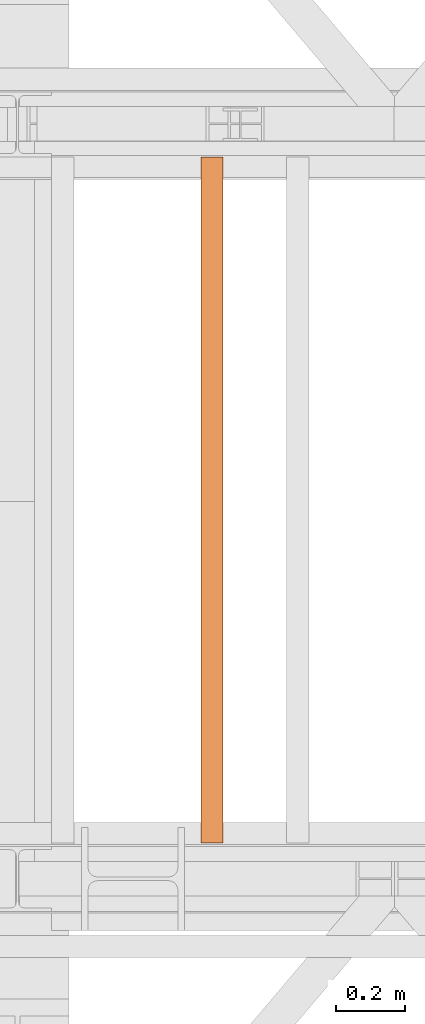
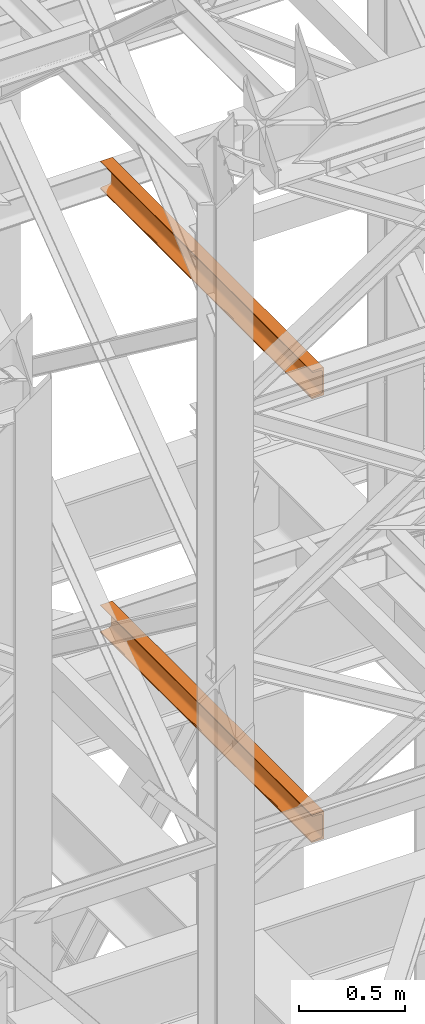
# One storey, part 156 of 208: 2 proxies.
"""IFC2X3 building model written with IfcOpenShell, lengths in millimetres."""

from ifc_helpers import new_model, entity, si_unit, converted_unit, frame, origin, origin_with_axes, place, context, subcontext, project, spatial, faceted_brep, element, save


model = new_model("IFC2X3")

# Units and contexts
model_context = context("Model", 3, precision=1e-05, world=origin())
plan_context = context("Plan", 3, precision=1e-05, world=origin())
body_context = subcontext(model_context, "Body", "Model", "MODEL_VIEW")
ifc_project = project(units=[si_unit("LENGTHUNIT", "METRE", prefix="MILLI"), converted_unit("PLANEANGLEUNIT", "DEGREE", entity("IfcPlaneAngleMeasure", 0.0174532925199433), si_unit("PLANEANGLEUNIT", "RADIAN"), dimensions=[0, 0, 0, 0, 0, 0, 0]), si_unit("AREAUNIT", "SQUARE_METRE"), si_unit("VOLUMEUNIT", "CUBIC_METRE")], contexts=[model_context, plan_context])

# Building, storey
building_placement = place(None, origin())
building = spatial("IfcBuilding", under=ifc_project, at=building_placement, CompositionType="COMPLEX")
storey_placement = place(building_placement, origin_with_axes())
storey = spatial("IfcBuildingStorey", under=building, at=storey_placement, Name="Geschoss", CompositionType="ELEMENT")

# Proxies
proxy_1_placement = place(storey_placement, frame((3828.254968528666, -15857.57439274273, 5524.960005364417), z_axis=(0.0, 0.0, 1.0), x_axis=(1.0, 0.0, 0.0)))
element("IfcBuildingElementProxy", 1, at=proxy_1_placement, inside=storey, context=body_context, shape_type="Brep", body=[
    faceted_brep([(65.01000000000022, 2000.009997019768, 160.0100000000002), (65.01000000000158, 0.01000000000021828, 160.0100000000002), (0.01000000000158252, 0.01000000000021828, 160.0100000000002), (0.01000000000021828, 2000.009997019768, 160.0100000000002), (0.01000000000021828, 2000.009997019768, 160.0100000000002), (0.01000000000158252, 0.01000000000021828, 160.0100000000002), (0.01000000000158252, 0.01000000000021828, 156.8875719297539), (0.01000000000021828, 2000.009997019768, 156.8875719297539), (0.01000000000021828, 2000.009997019768, 156.8875719297539), (0.01000000000158252, 0.01000000000021828, 156.8875719297539), (0.2527365771743462, 0.01000000000021828, 155.2717110918293), (0.2527365771729819, 2000.009997019768, 155.2717110918293), (0.2527365771729819, 2000.009997019768, 155.2717110918293), (0.2527365771743462, 0.01000000000021828, 155.2717110918293), (0.9594677141426473, 0.01000000000021828, 153.7984655565542), (0.959467714144921, 2000.009997019768, 153.7984655565542), (0.959467714144921, 2000.009997019768, 153.7984655565542), (0.9594677141426473, 0.01000000000021828, 153.7984655565542), (2.067848361533379, 0.01000000000021828, 152.5978732961266), (2.067848361532015, 2000.009997019768, 152.5978732961266), (2.067848361532015, 2000.009997019768, 152.5978732961266), (2.067848361533379, 0.01000000000021828, 152.5978732961266), (3.480043588518583, 0.01000000000021828, 151.7759086082897), (3.480043588517219, 2000.009997019768, 151.7759086082897), (3.480043588517219, 2000.009997019768, 151.7759086082897), (3.480043588518583, 0.01000000000021828, 151.7759086082897), (5.071401277447421, 0.01000000000021828, 151.4050878978051), (5.071401277446057, 2000.009997019768, 151.4050878978051), (5.071401277446057, 2000.009997019768, 151.4050878978051), (5.071401277447421, 0.01000000000021828, 151.4050878978051), (47.84732483397193, 0.01000000000021828, 147.9830140132835), (47.84732483397056, 2000.009997019768, 147.9830140132835), (47.84732483397056, 2000.009997019768, 147.9830140132835), (47.84732483397193, 0.01000000000021828, 147.9830140132835), (50.81159179199267, 0.01000000000021828, 147.318026761528), (50.8115917919913, 2000.009997019768, 147.318026761528), (50.8115917919913, 2000.009997019768, 147.318026761528), (50.81159179199267, 0.01000000000021828, 147.318026761528), (53.58138040071162, 0.01000000000021828, 145.7058782528511), (53.5813804007139, 2000.009997019768, 145.7058782528511), (53.5813804007139, 2000.009997019768, 145.7058782528511), (53.58138040071162, 0.01000000000021828, 145.7058782528511), (55.69737981845492, 0.01000000000021828, 143.4138384829421), (55.69737981845356, 2000.009997019768, 143.4138384829421), (55.69737981845356, 2000.009997019768, 143.4138384829421), (55.69737981845492, 0.01000000000021828, 143.4138384829421), (57.04659380721523, 0.01000000000021828, 140.6012788246917), (57.04659380721387, 2000.009997019768, 140.6012788246917), (57.04659380721387, 2000.009997019768, 140.6012788246917), (57.04659380721523, 0.01000000000021828, 140.6012788246917), (57.51000000000158, 0.01000000000021828, 137.5164535886543), (57.51000000000022, 2000.009997019768, 137.5164535886543), (57.51000000000022, 2000.009997019768, 137.5164535886543), (57.51000000000158, 0.01000000000021828, 137.5164535886543), (57.51000000000158, 0.01000000000021828, 22.503546411348), (57.51000000000022, 2000.009997019768, 22.503546411348), (57.51000000000022, 2000.009997019768, 22.503546411348), (57.51000000000158, 0.01000000000021828, 22.503546411348), (57.04659380721523, 0.01000000000021828, 19.41872117530875), (57.04659380721387, 2000.009997019768, 19.41872117530875), (57.04659380721387, 2000.009997019768, 19.41872117530875), (57.04659380721523, 0.01000000000021828, 19.41872117530875), (55.69737981845492, 0.01000000000021828, 16.60616151705835), (55.69737981845356, 2000.009997019768, 16.60616151705835), (55.69737981845356, 2000.009997019768, 16.60616151705835), (55.69737981845492, 0.01000000000021828, 16.60616151705835), (53.58138040071162, 0.01000000000021828, 14.31412174714933), (53.5813804007139, 2000.009997019768, 14.31412174714933), (53.5813804007139, 2000.009997019768, 14.31412174714933), (53.58138040071162, 0.01000000000021828, 14.31412174714933), (50.8853713310159, 0.01000000000021828, 12.74491643400688), (50.88537133101818, 2000.009997019768, 12.74491643400688), (50.88537133101818, 2000.009997019768, 12.74491643400688), (50.8853713310159, 0.01000000000021828, 12.74491643400688), (47.84732483397193, 0.01000000000021828, 12.03698598671872), (47.84732483397056, 2000.009997019768, 12.03698598671872), (47.84732483397056, 2000.009997019768, 12.03698598671872), (47.84732483397193, 0.01000000000021828, 12.03698598671872), (5.071401277447421, 0.01000000000021828, 8.614912102195376), (5.071401277446057, 2000.009997019768, 8.614912102195376), (5.071401277446057, 2000.009997019768, 8.614912102195376), (5.071401277447421, 0.01000000000021828, 8.614912102195376), (3.480043588518583, 0.01000000000021828, 8.244091391710754), (3.480043588517219, 2000.009997019768, 8.244091391710754), (3.480043588517219, 2000.009997019768, 8.244091391710754), (3.480043588518583, 0.01000000000021828, 8.244091391710754), (2.067848361533379, 0.01000000000021828, 7.422126703873801), (2.067848361532015, 2000.009997019768, 7.422126703873801), (2.067848361532015, 2000.009997019768, 7.422126703873801), (2.067848361533379, 0.01000000000021828, 7.422126703873801), (0.9594677141426473, 0.01000000000021828, 6.221534443446217), (0.959467714144921, 2000.009997019768, 6.221534443446217), (0.959467714144921, 2000.009997019768, 6.221534443446217), (0.9594677141426473, 0.01000000000021828, 6.221534443446217), (0.2527365771743462, 0.01000000000021828, 4.748288908172981), (0.2527365771729819, 2000.009997019768, 4.748288908172981), (0.2527365771729819, 2000.009997019768, 4.748288908172981), (0.2527365771743462, 0.01000000000021828, 4.748288908172981), (0.01000000000158252, 0.01000000000021828, 0.01000000000021828), (0.01000000000021828, 2000.009997019768, 0.01000000000021828), (0.01000000000021828, 2000.009997019768, 0.01000000000021828), (0.01000000000158252, 0.01000000000021828, 0.01000000000021828), (65.01000000000158, 0.01000000000021828, 0.01000000000021828), (65.01000000000022, 2000.009997019768, 0.01000000000021828), (65.01000000000022, 2000.009997019768, 0.01000000000021828), (65.01000000000158, 0.01000000000021828, 0.01000000000021828), (65.01000000000158, 0.01000000000021828, 160.0100000000002), (65.01000000000022, 2000.009997019768, 160.0100000000002), (65.01000000000022, 2000.009997019768, 160.0100000000002), (0.01000000000021828, 2000.009997019768, 160.0100000000002), (0.01000000000021828, 2000.009997019768, 156.8875719297539), (0.2527365771729819, 2000.009997019768, 155.2717110918293), (0.959467714144921, 2000.009997019768, 153.7984655565542), (2.067848361532015, 2000.009997019768, 152.5978732961266), (3.480043588517219, 2000.009997019768, 151.7759086082897), (5.071401277446057, 2000.009997019768, 151.4050878978051), (47.84732483397056, 2000.009997019768, 147.9830140132835), (50.8115917919913, 2000.009997019768, 147.318026761528), (53.5813804007139, 2000.009997019768, 145.7058782528511), (55.69737981845356, 2000.009997019768, 143.4138384829421), (57.04659380721387, 2000.009997019768, 140.6012788246917), (57.51000000000022, 2000.009997019768, 137.5164535886543), (57.51000000000022, 2000.009997019768, 22.503546411348), (57.04659380721387, 2000.009997019768, 19.41872117530875), (55.69737981845356, 2000.009997019768, 16.60616151705835), (53.5813804007139, 2000.009997019768, 14.31412174714933), (50.88537133101818, 2000.009997019768, 12.74491643400688), (47.84732483397056, 2000.009997019768, 12.03698598671872), (5.071401277446057, 2000.009997019768, 8.614912102195376), (3.480043588517219, 2000.009997019768, 8.244091391710754), (2.067848361532015, 2000.009997019768, 7.422126703873801), (0.959467714144921, 2000.009997019768, 6.221534443446217), (0.2527365771729819, 2000.009997019768, 4.748288908172981), (0.01000000000021828, 2000.009997019768, 0.01000000000021828), (65.01000000000022, 2000.009997019768, 0.01000000000021828), (65.01000000000158, 0.01000000000021828, 160.0100000000002), (65.01000000000158, 0.01000000000021828, 0.01000000000021828), (0.01000000000158252, 0.01000000000021828, 0.01000000000021828), (0.2527365771743462, 0.01000000000021828, 4.748288908172981), (0.9594677141426473, 0.01000000000021828, 6.221534443446217), (2.067848361533379, 0.01000000000021828, 7.422126703873801), (3.480043588518583, 0.01000000000021828, 8.244091391710754), (5.071401277447421, 0.01000000000021828, 8.614912102195376), (47.84732483397193, 0.01000000000021828, 12.03698598671872), (50.8853713310159, 0.01000000000021828, 12.74491643400688), (53.58138040071162, 0.01000000000021828, 14.31412174714933), (55.69737981845492, 0.01000000000021828, 16.60616151705835), (57.04659380721523, 0.01000000000021828, 19.41872117530875), (57.51000000000158, 0.01000000000021828, 22.503546411348), (57.51000000000158, 0.01000000000021828, 137.5164535886543), (57.04659380721523, 0.01000000000021828, 140.6012788246917), (55.69737981845492, 0.01000000000021828, 143.4138384829421), (53.58138040071162, 0.01000000000021828, 145.7058782528511), (50.81159179199267, 0.01000000000021828, 147.318026761528), (47.84732483397193, 0.01000000000021828, 147.9830140132835), (5.071401277447421, 0.01000000000021828, 151.4050878978051), (3.480043588518583, 0.01000000000021828, 151.7759086082897), (2.067848361533379, 0.01000000000021828, 152.5978732961266), (0.9594677141426473, 0.01000000000021828, 153.7984655565542), (0.2527365771743462, 0.01000000000021828, 155.2717110918293), (0.01000000000158252, 0.01000000000021828, 156.8875719297539), (0.01000000000158252, 0.01000000000021828, 160.0100000000002)], [[[0, 1, 2, 3]], [[4, 5, 6, 7]], [[8, 9, 10, 11]], [[12, 13, 14, 15]], [[16, 17, 18, 19]], [[20, 21, 22, 23]], [[24, 25, 26, 27]], [[28, 29, 30, 31]], [[32, 33, 34, 35]], [[36, 37, 38, 39]], [[40, 41, 42, 43]], [[44, 45, 46, 47]], [[48, 49, 50, 51]], [[52, 53, 54, 55]], [[56, 57, 58, 59]], [[60, 61, 62, 63]], [[64, 65, 66, 67]], [[68, 69, 70, 71]], [[72, 73, 74, 75]], [[76, 77, 78, 79]], [[80, 81, 82, 83]], [[84, 85, 86, 87]], [[88, 89, 90, 91]], [[92, 93, 94, 95]], [[96, 97, 98, 99]], [[100, 101, 102, 103]], [[104, 105, 106, 107]], [[108, 109, 110, 111, 112, 113, 114, 115, 116, 117, 118, 119, 120, 121, 122, 123, 124, 125, 126, 127, 128, 129, 130, 131, 132, 133, 134]], [[135, 136, 137, 138, 139, 140, 141, 142, 143, 144, 145, 146, 147, 148, 149, 150, 151, 152, 153, 154, 155, 156, 157, 158, 159, 160, 161]]], orient=[[False], [False], [False], [False], [False], [False], [False], [False], [False], [False], [False], [False], [False], [False], [False], [False], [False], [False], [False], [False], [False], [False], [False], [False], [False], [False], [False], [False], [False]]),
])
proxy_2_placement = place(storey_placement, frame((3828.254968528666, -15857.57439274273, 8084.960005364417), z_axis=(0.0, 0.0, 1.0), x_axis=(1.0, 0.0, 0.0)))
element("IfcBuildingElementProxy", 2, at=proxy_2_placement, inside=storey, context=body_context, shape_type="Brep", body=[
    faceted_brep([(65.01000000000022, 2000.009997019768, 160.0100000000002), (65.01000000000158, 0.01000000000021828, 160.0100000000002), (0.01000000000158252, 0.01000000000021828, 160.0100000000002), (0.01000000000021828, 2000.009997019768, 160.0100000000002), (0.01000000000021828, 2000.009997019768, 160.0100000000002), (0.01000000000158252, 0.01000000000021828, 160.0100000000002), (0.01000000000158252, 0.01000000000021828, 156.8875719297539), (0.01000000000021828, 2000.009997019768, 156.8875719297539), (0.01000000000021828, 2000.009997019768, 156.8875719297539), (0.01000000000158252, 0.01000000000021828, 156.8875719297539), (0.2527365771743462, 0.01000000000021828, 155.2717110918293), (0.2527365771729819, 2000.009997019768, 155.2717110918293), (0.2527365771729819, 2000.009997019768, 155.2717110918293), (0.2527365771743462, 0.01000000000021828, 155.2717110918293), (0.9594677141426473, 0.01000000000021828, 153.7984655565542), (0.959467714144921, 2000.009997019768, 153.7984655565542), (0.959467714144921, 2000.009997019768, 153.7984655565542), (0.9594677141426473, 0.01000000000021828, 153.7984655565542), (2.067848361533379, 0.01000000000021828, 152.5978732961266), (2.067848361532015, 2000.009997019768, 152.5978732961266), (2.067848361532015, 2000.009997019768, 152.5978732961266), (2.067848361533379, 0.01000000000021828, 152.5978732961266), (3.480043588518583, 0.01000000000021828, 151.7759086082897), (3.480043588517219, 2000.009997019768, 151.7759086082897), (3.480043588517219, 2000.009997019768, 151.7759086082897), (3.480043588518583, 0.01000000000021828, 151.7759086082897), (5.071401277447421, 0.01000000000021828, 151.4050878978051), (5.071401277446057, 2000.009997019768, 151.4050878978051), (5.071401277446057, 2000.009997019768, 151.4050878978051), (5.071401277447421, 0.01000000000021828, 151.4050878978051), (47.84732483397193, 0.01000000000021828, 147.9830140132835), (47.84732483397056, 2000.009997019768, 147.9830140132835), (47.84732483397056, 2000.009997019768, 147.9830140132835), (47.84732483397193, 0.01000000000021828, 147.9830140132835), (50.81159179199267, 0.01000000000021828, 147.318026761528), (50.8115917919913, 2000.009997019768, 147.318026761528), (50.8115917919913, 2000.009997019768, 147.318026761528), (50.81159179199267, 0.01000000000021828, 147.318026761528), (53.58138040071162, 0.01000000000021828, 145.7058782528511), (53.5813804007139, 2000.009997019768, 145.7058782528511), (53.5813804007139, 2000.009997019768, 145.7058782528511), (53.58138040071162, 0.01000000000021828, 145.7058782528511), (55.69737981845492, 0.01000000000021828, 143.4138384829421), (55.69737981845356, 2000.009997019768, 143.4138384829421), (55.69737981845356, 2000.009997019768, 143.4138384829421), (55.69737981845492, 0.01000000000021828, 143.4138384829421), (57.04659380721523, 0.01000000000021828, 140.6012788246917), (57.04659380721387, 2000.009997019768, 140.6012788246917), (57.04659380721387, 2000.009997019768, 140.6012788246917), (57.04659380721523, 0.01000000000021828, 140.6012788246917), (57.51000000000158, 0.01000000000021828, 137.5164535886543), (57.51000000000022, 2000.009997019768, 137.5164535886543), (57.51000000000022, 2000.009997019768, 137.5164535886543), (57.51000000000158, 0.01000000000021828, 137.5164535886543), (57.51000000000158, 0.01000000000021828, 22.503546411348), (57.51000000000022, 2000.009997019768, 22.503546411348), (57.51000000000022, 2000.009997019768, 22.503546411348), (57.51000000000158, 0.01000000000021828, 22.503546411348), (57.04659380721523, 0.01000000000021828, 19.41872117530875), (57.04659380721387, 2000.009997019768, 19.41872117530875), (57.04659380721387, 2000.009997019768, 19.41872117530875), (57.04659380721523, 0.01000000000021828, 19.41872117530875), (55.69737981845492, 0.01000000000021828, 16.60616151705835), (55.69737981845356, 2000.009997019768, 16.60616151705835), (55.69737981845356, 2000.009997019768, 16.60616151705835), (55.69737981845492, 0.01000000000021828, 16.60616151705835), (53.58138040071162, 0.01000000000021828, 14.31412174714933), (53.5813804007139, 2000.009997019768, 14.31412174714933), (53.5813804007139, 2000.009997019768, 14.31412174714933), (53.58138040071162, 0.01000000000021828, 14.31412174714933), (50.8853713310159, 0.01000000000021828, 12.74491643400688), (50.88537133101818, 2000.009997019768, 12.74491643400688), (50.88537133101818, 2000.009997019768, 12.74491643400688), (50.8853713310159, 0.01000000000021828, 12.74491643400688), (47.84732483397193, 0.01000000000021828, 12.03698598671872), (47.84732483397056, 2000.009997019768, 12.03698598671872), (47.84732483397056, 2000.009997019768, 12.03698598671872), (47.84732483397193, 0.01000000000021828, 12.03698598671872), (5.071401277447421, 0.01000000000021828, 8.614912102195376), (5.071401277446057, 2000.009997019768, 8.614912102195376), (5.071401277446057, 2000.009997019768, 8.614912102195376), (5.071401277447421, 0.01000000000021828, 8.614912102195376), (3.480043588518583, 0.01000000000021828, 8.244091391710754), (3.480043588517219, 2000.009997019768, 8.244091391710754), (3.480043588517219, 2000.009997019768, 8.244091391710754), (3.480043588518583, 0.01000000000021828, 8.244091391710754), (2.067848361533379, 0.01000000000021828, 7.422126703873801), (2.067848361532015, 2000.009997019768, 7.422126703873801), (2.067848361532015, 2000.009997019768, 7.422126703873801), (2.067848361533379, 0.01000000000021828, 7.422126703873801), (0.9594677141426473, 0.01000000000021828, 6.221534443446217), (0.959467714144921, 2000.009997019768, 6.221534443446217), (0.959467714144921, 2000.009997019768, 6.221534443446217), (0.9594677141426473, 0.01000000000021828, 6.221534443446217), (0.2527365771743462, 0.01000000000021828, 4.748288908172981), (0.2527365771729819, 2000.009997019768, 4.748288908172981), (0.2527365771729819, 2000.009997019768, 4.748288908172981), (0.2527365771743462, 0.01000000000021828, 4.748288908172981), (0.01000000000158252, 0.01000000000021828, 0.01000000000021828), (0.01000000000021828, 2000.009997019768, 0.01000000000021828), (0.01000000000021828, 2000.009997019768, 0.01000000000021828), (0.01000000000158252, 0.01000000000021828, 0.01000000000021828), (65.01000000000158, 0.01000000000021828, 0.01000000000021828), (65.01000000000022, 2000.009997019768, 0.01000000000021828), (65.01000000000022, 2000.009997019768, 0.01000000000021828), (65.01000000000158, 0.01000000000021828, 0.01000000000021828), (65.01000000000158, 0.01000000000021828, 160.0100000000002), (65.01000000000022, 2000.009997019768, 160.0100000000002), (65.01000000000022, 2000.009997019768, 160.0100000000002), (0.01000000000021828, 2000.009997019768, 160.0100000000002), (0.01000000000021828, 2000.009997019768, 156.8875719297539), (0.2527365771729819, 2000.009997019768, 155.2717110918293), (0.959467714144921, 2000.009997019768, 153.7984655565542), (2.067848361532015, 2000.009997019768, 152.5978732961266), (3.480043588517219, 2000.009997019768, 151.7759086082897), (5.071401277446057, 2000.009997019768, 151.4050878978051), (47.84732483397056, 2000.009997019768, 147.9830140132835), (50.8115917919913, 2000.009997019768, 147.318026761528), (53.5813804007139, 2000.009997019768, 145.7058782528511), (55.69737981845356, 2000.009997019768, 143.4138384829421), (57.04659380721387, 2000.009997019768, 140.6012788246917), (57.51000000000022, 2000.009997019768, 137.5164535886543), (57.51000000000022, 2000.009997019768, 22.503546411348), (57.04659380721387, 2000.009997019768, 19.41872117530875), (55.69737981845356, 2000.009997019768, 16.60616151705835), (53.5813804007139, 2000.009997019768, 14.31412174714933), (50.88537133101818, 2000.009997019768, 12.74491643400688), (47.84732483397056, 2000.009997019768, 12.03698598671872), (5.071401277446057, 2000.009997019768, 8.614912102195376), (3.480043588517219, 2000.009997019768, 8.244091391710754), (2.067848361532015, 2000.009997019768, 7.422126703873801), (0.959467714144921, 2000.009997019768, 6.221534443446217), (0.2527365771729819, 2000.009997019768, 4.748288908172981), (0.01000000000021828, 2000.009997019768, 0.01000000000021828), (65.01000000000022, 2000.009997019768, 0.01000000000021828), (65.01000000000158, 0.01000000000021828, 160.0100000000002), (65.01000000000158, 0.01000000000021828, 0.01000000000021828), (0.01000000000158252, 0.01000000000021828, 0.01000000000021828), (0.2527365771743462, 0.01000000000021828, 4.748288908172981), (0.9594677141426473, 0.01000000000021828, 6.221534443446217), (2.067848361533379, 0.01000000000021828, 7.422126703873801), (3.480043588518583, 0.01000000000021828, 8.244091391710754), (5.071401277447421, 0.01000000000021828, 8.614912102195376), (47.84732483397193, 0.01000000000021828, 12.03698598671872), (50.8853713310159, 0.01000000000021828, 12.74491643400688), (53.58138040071162, 0.01000000000021828, 14.31412174714933), (55.69737981845492, 0.01000000000021828, 16.60616151705835), (57.04659380721523, 0.01000000000021828, 19.41872117530875), (57.51000000000158, 0.01000000000021828, 22.503546411348), (57.51000000000158, 0.01000000000021828, 137.5164535886543), (57.04659380721523, 0.01000000000021828, 140.6012788246917), (55.69737981845492, 0.01000000000021828, 143.4138384829421), (53.58138040071162, 0.01000000000021828, 145.7058782528511), (50.81159179199267, 0.01000000000021828, 147.318026761528), (47.84732483397193, 0.01000000000021828, 147.9830140132835), (5.071401277447421, 0.01000000000021828, 151.4050878978051), (3.480043588518583, 0.01000000000021828, 151.7759086082897), (2.067848361533379, 0.01000000000021828, 152.5978732961266), (0.9594677141426473, 0.01000000000021828, 153.7984655565542), (0.2527365771743462, 0.01000000000021828, 155.2717110918293), (0.01000000000158252, 0.01000000000021828, 156.8875719297539), (0.01000000000158252, 0.01000000000021828, 160.0100000000002)], [[[0, 1, 2, 3]], [[4, 5, 6, 7]], [[8, 9, 10, 11]], [[12, 13, 14, 15]], [[16, 17, 18, 19]], [[20, 21, 22, 23]], [[24, 25, 26, 27]], [[28, 29, 30, 31]], [[32, 33, 34, 35]], [[36, 37, 38, 39]], [[40, 41, 42, 43]], [[44, 45, 46, 47]], [[48, 49, 50, 51]], [[52, 53, 54, 55]], [[56, 57, 58, 59]], [[60, 61, 62, 63]], [[64, 65, 66, 67]], [[68, 69, 70, 71]], [[72, 73, 74, 75]], [[76, 77, 78, 79]], [[80, 81, 82, 83]], [[84, 85, 86, 87]], [[88, 89, 90, 91]], [[92, 93, 94, 95]], [[96, 97, 98, 99]], [[100, 101, 102, 103]], [[104, 105, 106, 107]], [[108, 109, 110, 111, 112, 113, 114, 115, 116, 117, 118, 119, 120, 121, 122, 123, 124, 125, 126, 127, 128, 129, 130, 131, 132, 133, 134]], [[135, 136, 137, 138, 139, 140, 141, 142, 143, 144, 145, 146, 147, 148, 149, 150, 151, 152, 153, 154, 155, 156, 157, 158, 159, 160, 161]]], orient=[[False], [False], [False], [False], [False], [False], [False], [False], [False], [False], [False], [False], [False], [False], [False], [False], [False], [False], [False], [False], [False], [False], [False], [False], [False], [False], [False], [False], [False]]),
])

save(model, "model.ifc")
